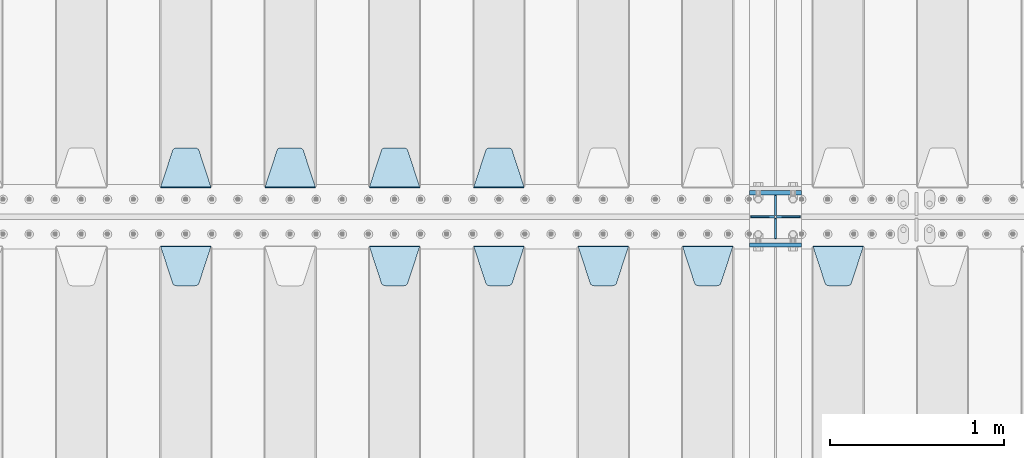
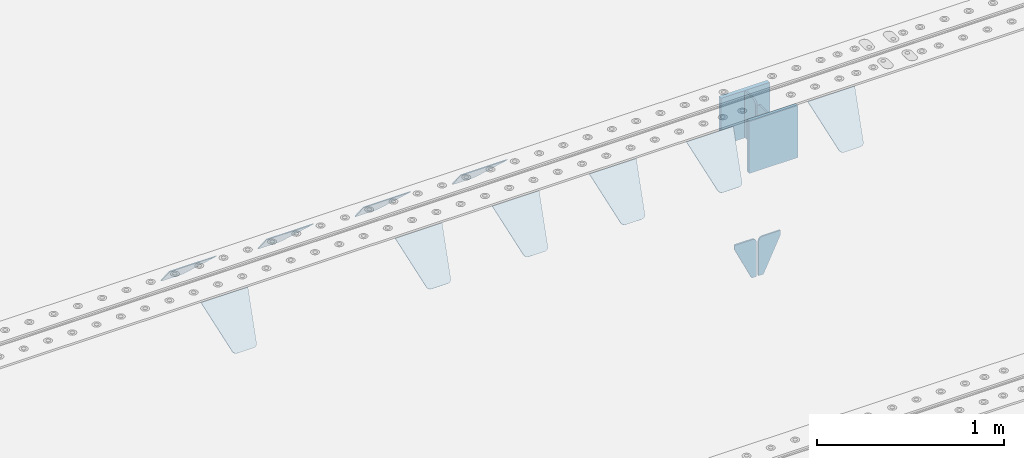
# One storey, part 205 of 240: 16 plates.
"""IFC2X3 building model written with IfcOpenShell, lengths in millimetres."""

from ifc_helpers import new_model, si_unit, frame, origin_with_axes, place, context, subcontext, project, spatial, faceted_brep, material, type_object, element, save


model = new_model("IFC2X3")

# Units and contexts
model_context = context("Model", 3, precision=1e-05, world=origin_with_axes())
body_context = subcontext(model_context, "Body", "Model", "MODEL_VIEW")
ifc_project = project(units=[si_unit("LENGTHUNIT", "METRE", prefix="MILLI"), si_unit("AREAUNIT", "SQUARE_METRE"), si_unit("VOLUMEUNIT", "CUBIC_METRE"), si_unit("MASSUNIT", "GRAM", prefix="KILO"), si_unit("TIMEUNIT", "SECOND"), si_unit("PLANEANGLEUNIT", "RADIAN"), si_unit("SOLIDANGLEUNIT", "STERADIAN"), si_unit("THERMODYNAMICTEMPERATUREUNIT", "DEGREE_CELSIUS"), si_unit("LUMINOUSINTENSITYUNIT", "LUMEN")], contexts=[model_context])

# Site, building, storey
site_placement = place(None, origin_with_axes())
site = spatial("IfcSite", under=ifc_project, at=site_placement, CompositionType="ELEMENT")
building_placement = place(site_placement, origin_with_axes())
building = spatial("IfcBuilding", under=site, at=building_placement, Name="Standard", CompositionType="ELEMENT")
storey_placement = place(building_placement, origin_with_axes())
storey = spatial("IfcBuildingStorey", under=building, at=storey_placement, Name="Undefined", CompositionType="ELEMENT", Elevation=0.0)

# Plates
ifc_material = material(Name="STEEL/S355N")
plate_type_1 = type_object("IfcPlateType", PredefinedType="NOTDEFINED")
plate_1_placement = place(storey_placement, frame((52690.0, 29837.5, -340.000000000044), z_axis=(0.0, 0.0, 1.0), x_axis=(1.0, 0.0, 0.0)))
element("IfcPlate", 1, at=plate_1_placement, inside=storey, type_object=plate_type_1, material=ifc_material, context=body_context, shape_type="Brep", body=[
    faceted_brep([(0.0, -12.5, 0.0), (9.31322574615479e-10, -12.5, 340.0), (9.31322574615479e-10, 12.5, 340.0), (0.0, 12.5, 0.0), (300.0, -12.5, 340.0), (300.0, 12.5, 340.0), (300.0, -12.5, 0.0), (300.0, 12.5, 0.0)], [[[0, 1, 2, 3]], [[1, 4, 5, 2]], [[4, 6, 7, 5]], [[6, 0, 3, 7]], [[5, 7, 3, 2]], [[6, 4, 1, 0]]]),
])
plate_2_placement = place(storey_placement, frame((52690.0, 30137.5, -340.0), z_axis=(0.0, 0.0, 1.0), x_axis=(1.0, 0.0, 0.0)))
element("IfcPlate", 2, at=plate_2_placement, inside=storey, type_object=plate_type_1, material=ifc_material, context=body_context, shape_type="Brep", body=[
    faceted_brep([(0.0, -12.5, 0.0), (0.0, -12.5, 310.0), (0.0, 12.5, 310.0), (0.0, 12.5, 0.0), (300.0, -12.5, 310.0), (300.0, 12.5, 310.0), (300.0, -12.5, 0.0), (300.0, 12.5, 0.0)], [[[0, 1, 2, 3]], [[1, 4, 5, 2]], [[4, 6, 7, 5]], [[6, 0, 3, 7]], [[5, 7, 3, 2]], [[6, 4, 1, 0]]]),
])
plate_type_2 = type_object("IfcPlateType", PredefinedType="NOTDEFINED")
for number, where, z_axis, x_axis in (
    (3, (52840.0, 30008.0, -30.0), (0.0, 0.0, -1.0), (0.0, 1.0, 0.0)),
    (4, (52840.0, 29992.0, -30.0), (0.0, 0.0, -1.0), (0.0, -1.0, 0.0)),
):
    element("IfcPlate", number, at=place(storey_placement, frame(where, z_axis=z_axis, x_axis=x_axis)), inside=storey, type_object=plate_type_2, material=ifc_material, context=body_context, shape_type="Brep", body=[
        faceted_brep([(0.0, -5.0, 30.0), (0.0, -5.0, 306.0), (0.0, 5.0, 306.0), (0.0, 5.0, 30.0), (117.0, -5.0, 306.0), (117.0, 5.0, 306.0), (117.0, -5.0, 0.0), (117.0, 5.0, 0.0), (30.0, -5.0, 0.0), (30.0, 5.0, 0.0), (24.7905546699913, -5.0, 0.455767409633758), (24.7905546699913, 5.0, 0.455767409633758), (19.7393957002278, -5.0, 1.80922137642275), (19.7393957002278, 5.0, 1.80922137642275), (15.0, -5.0, 4.01923788646684), (15.0, 5.0, 4.01923788646684), (10.7163717094008, -5.0, 7.01866670643066), (10.7163717094008, 5.0, 7.01866670643066), (7.01866670643358, -5.0, 10.7163717094038), (7.01866670643358, 5.0, 10.7163717094038), (4.01923788646673, -5.0, 15.0), (4.01923788646673, 5.0, 15.0), (1.80922137642483, -5.0, 19.7393957002299), (1.80922137642483, 5.0, 19.7393957002299), (0.455767409635882, -5.0, 24.7905546699921), (0.455767409635882, 5.0, 24.7905546699921)], [[[0, 1, 2, 3]], [[1, 4, 5, 2]], [[4, 6, 7, 5]], [[6, 8, 9, 7]], [[8, 10, 11, 9]], [[10, 12, 13, 11]], [[12, 14, 15, 13]], [[14, 16, 17, 15]], [[16, 18, 19, 17]], [[18, 20, 21, 19]], [[20, 22, 23, 21]], [[22, 24, 25, 23]], [[24, 0, 3, 25]], [[5, 7, 9, 11, 13, 15, 17, 19, 21, 23, 25, 3, 2]], [[24, 22, 20, 18, 16, 14, 12, 10, 8, 6, 4, 1, 0]]]),
    ])
plate_type_3 = type_object("IfcPlateType", PredefinedType="NOTDEFINED")
for number, where, z_axis, x_axis in (
    (5, (52833.4999999979, 30000.0000000345, -915.000018222273), (0.0, 0.0, -1.0), (-1.0, 0.0, 0.0)),
    (6, (52846.4999999981, 30000.0000000345, -915.000018222273), (0.0, 0.0, -1.0), (1.0, 0.0, 0.0)),
):
    element("IfcPlate", number, at=place(storey_placement, frame(where, z_axis=z_axis, x_axis=x_axis)), inside=storey, type_object=plate_type_3, material=ifc_material, context=body_context, shape_type="Brep", body=[
        faceted_brep([(0.0, -5.0, 27.0), (0.0, -5.0, 250.0), (0.0, 5.0, 250.0), (0.0, 5.0, 27.0), (30.0, -5.0, 250.0), (30.0, 5.0, 250.0), (135.0, -5.0, 30.0), (135.0, 5.0, 30.0), (135.0, -5.0, 0.0), (135.0, 5.0, 0.0), (27.0, -5.0, 0.0), (27.0, 5.0, 0.0), (22.311499202995, -5.0, 0.410190668670339), (22.311499202995, 5.0, 0.410190668670339), (17.7654561302043, -5.0, 1.62829923878053), (17.7654561302043, 5.0, 1.62829923878053), (13.5, -5.0, 3.6173140978201), (13.5, 5.0, 3.6173140978201), (9.64473453846585, -5.0, 6.31680003578754), (9.64473453846585, 5.0, 6.31680003578754), (6.31680003579095, -5.0, 9.64473453846347), (6.31680003579095, 5.0, 9.64473453846347), (3.61731409782078, -5.0, 13.5), (3.61731409782078, 5.0, 13.5), (1.62829923877871, -5.0, 17.765456130207), (1.62829923877871, 5.0, 17.765456130207), (0.410190668670111, -5.0, 22.3114992029929), (0.410190668670111, 5.0, 22.3114992029929)], [[[0, 1, 2, 3]], [[1, 4, 5, 2]], [[4, 6, 7, 5]], [[6, 8, 9, 7]], [[8, 10, 11, 9]], [[10, 12, 13, 11]], [[12, 14, 15, 13]], [[14, 16, 17, 15]], [[16, 18, 19, 17]], [[18, 20, 21, 19]], [[20, 22, 23, 21]], [[22, 24, 25, 23]], [[24, 26, 27, 25]], [[26, 0, 3, 27]], [[5, 7, 9, 11, 13, 15, 17, 19, 21, 23, 25, 27, 3, 2]], [[26, 24, 22, 20, 18, 16, 14, 12, 10, 8, 6, 4, 1, 0]]]),
    ])
plate_type_4 = type_object("IfcPlateType", PredefinedType="NOTDEFINED")
plate_3_placement = place(storey_placement, frame((51395.0, 30168.232233047, -1.76776695296758), z_axis=(0.0, 0.707106781186547, -0.707106781186548), x_axis=(-1.0, 0.0, 0.0)))
element("IfcPlate", 7, at=plate_3_placement, inside=storey, type_object=plate_type_4, material=ifc_material, context=body_context, shape_type="Brep", body=[
    faceted_brep([(0.0, -2.5, 0.0), (69.345504679477, -2.50000000000364, 300.171731424827), (69.345504679477, 2.49999999999636, 300.171731424827), (0.0, 2.5, 0.0), (70.927406119954, -2.50000000000364, 304.897442415397), (70.927406119954, 2.49999999999636, 304.897442415397), (73.3818627772271, -2.50000000000728, 309.234538108525), (73.3818627772271, 2.49999999999636, 309.234538108529), (76.6187032999587, -2.50000000000728, 313.023683126099), (76.6187032999587, 2.49999999999636, 313.023683126103), (80.5190132705029, -2.50000000000364, 316.125672595368), (80.5190132705029, 2.49999999999636, 316.125672595368), (84.9395038596849, -2.50000000000364, 318.426546230472), (84.9395038596849, 2.49999999999636, 318.426546230472), (89.7177759439219, -2.5, 319.841774983277), (89.7177759439219, 2.49999999999636, 319.841774983273), (94.6782862926484, -2.50000000000364, 320.319366455074), (94.6782862926484, 2.49999999999636, 320.319366455074), (195.321713707352, -2.50000000000364, 320.319366455074), (195.321713707352, 2.49999999999636, 320.319366455074), (200.282224056078, -2.50000000000364, 319.841774983273), (200.282224056078, 2.49999999999636, 319.841774983273), (205.060496140315, -2.50000000000364, 318.426546230472), (205.060496140315, 2.49999999999636, 318.426546230472), (209.480986729497, -2.50000000000364, 316.125672595368), (209.480986729497, 2.49999999999636, 316.125672595368), (213.381296700041, -2.50000000000728, 313.023683126099), (213.381296700041, 2.49999999999272, 313.023683126099), (216.618137222766, -2.50000000000364, 309.234538108522), (216.618137222766, 2.49999999999636, 309.234538108522), (219.072593880039, -2.50000000000364, 304.897442415397), (219.072593880039, 2.49999999999636, 304.897442415397), (220.654495320523, -2.50000000000364, 300.171731424827), (220.654495320523, 2.49999999999636, 300.171731424827), (290.0, -2.50000000000364, -3.63797880709171e-12), (290.0, 2.49999999999636, -3.63797880709171e-12)], [[[0, 1, 2, 3]], [[1, 4, 5, 2]], [[4, 6, 7, 5]], [[6, 8, 9, 7]], [[8, 10, 11, 9]], [[10, 12, 13, 11]], [[12, 14, 15, 13]], [[14, 16, 17, 15]], [[16, 18, 19, 17]], [[18, 20, 21, 19]], [[20, 22, 23, 21]], [[22, 24, 25, 23]], [[24, 26, 27, 25]], [[26, 28, 29, 27]], [[28, 30, 31, 29]], [[30, 32, 33, 31]], [[32, 34, 35, 33]], [[34, 0, 3, 35]], [[5, 7, 9, 11, 13, 15, 17, 19, 21, 23, 25, 27, 29, 31, 33, 35, 3, 2]], [[34, 32, 30, 28, 26, 24, 22, 20, 18, 16, 14, 12, 10, 8, 6, 4, 1, 0]]]),
])
plate_4_placement = place(storey_placement, frame((50795.0, 30168.232233047, -1.76776695296758), z_axis=(0.0, 0.707106781186547, -0.707106781186548), x_axis=(-1.0, 0.0, 0.0)))
element("IfcPlate", 8, at=plate_4_placement, inside=storey, type_object=plate_type_4, material=ifc_material, context=body_context, shape_type="Brep", body=[
    faceted_brep([(0.0, -2.5, 0.0), (69.345504679477, -2.50000000000364, 300.171731424827), (69.345504679477, 2.49999999999636, 300.171731424827), (0.0, 2.5, 0.0), (70.927406119954, -2.50000000000364, 304.897442415397), (70.927406119954, 2.49999999999636, 304.897442415397), (73.3818627772271, -2.50000000000728, 309.234538108525), (73.3818627772271, 2.49999999999636, 309.234538108529), (76.6187032999587, -2.50000000000728, 313.023683126099), (76.6187032999587, 2.49999999999636, 313.023683126103), (80.5190132705029, -2.50000000000364, 316.125672595368), (80.5190132705029, 2.49999999999636, 316.125672595368), (84.9395038596849, -2.50000000000364, 318.426546230472), (84.9395038596849, 2.49999999999636, 318.426546230472), (89.7177759439219, -2.5, 319.841774983277), (89.7177759439219, 2.49999999999636, 319.841774983273), (94.6782862926484, -2.50000000000364, 320.319366455074), (94.6782862926484, 2.49999999999636, 320.319366455074), (195.321713707352, -2.50000000000364, 320.319366455074), (195.321713707352, 2.49999999999636, 320.319366455074), (200.282224056078, -2.50000000000364, 319.841774983273), (200.282224056078, 2.49999999999636, 319.841774983273), (205.060496140315, -2.50000000000364, 318.426546230472), (205.060496140315, 2.49999999999636, 318.426546230472), (209.480986729497, -2.50000000000364, 316.125672595368), (209.480986729497, 2.49999999999636, 316.125672595368), (213.381296700041, -2.50000000000728, 313.023683126099), (213.381296700041, 2.49999999999272, 313.023683126099), (216.618137222766, -2.50000000000364, 309.234538108522), (216.618137222766, 2.49999999999636, 309.234538108522), (219.072593880039, -2.50000000000364, 304.897442415397), (219.072593880039, 2.49999999999636, 304.897442415397), (220.654495320523, -2.50000000000364, 300.171731424827), (220.654495320523, 2.49999999999636, 300.171731424827), (290.0, -2.50000000000364, -3.63797880709171e-12), (290.0, 2.49999999999636, -3.63797880709171e-12)], [[[0, 1, 2, 3]], [[1, 4, 5, 2]], [[4, 6, 7, 5]], [[6, 8, 9, 7]], [[8, 10, 11, 9]], [[10, 12, 13, 11]], [[12, 14, 15, 13]], [[14, 16, 17, 15]], [[16, 18, 19, 17]], [[18, 20, 21, 19]], [[20, 22, 23, 21]], [[22, 24, 25, 23]], [[24, 26, 27, 25]], [[26, 28, 29, 27]], [[28, 30, 31, 29]], [[30, 32, 33, 31]], [[32, 34, 35, 33]], [[34, 0, 3, 35]], [[5, 7, 9, 11, 13, 15, 17, 19, 21, 23, 25, 27, 29, 31, 33, 35, 3, 2]], [[34, 32, 30, 28, 26, 24, 22, 20, 18, 16, 14, 12, 10, 8, 6, 4, 1, 0]]]),
])
plate_5_placement = place(storey_placement, frame((50195.0, 30168.232233047, -1.76776695296758), z_axis=(0.0, 0.707106781186547, -0.707106781186548), x_axis=(-1.0, 0.0, 0.0)))
element("IfcPlate", 9, at=plate_5_placement, inside=storey, type_object=plate_type_4, material=ifc_material, context=body_context, shape_type="Brep", body=[
    faceted_brep([(0.0, -2.5, 0.0), (69.345504679477, -2.50000000000364, 300.171731424827), (69.345504679477, 2.49999999999636, 300.171731424827), (0.0, 2.5, 0.0), (70.927406119954, -2.50000000000364, 304.897442415397), (70.927406119954, 2.49999999999636, 304.897442415397), (73.3818627772271, -2.50000000000728, 309.234538108525), (73.3818627772271, 2.49999999999636, 309.234538108529), (76.6187032999587, -2.50000000000728, 313.023683126099), (76.6187032999587, 2.49999999999636, 313.023683126103), (80.5190132705029, -2.50000000000364, 316.125672595368), (80.5190132705029, 2.49999999999636, 316.125672595368), (84.9395038596849, -2.50000000000364, 318.426546230472), (84.9395038596849, 2.49999999999636, 318.426546230472), (89.7177759439219, -2.5, 319.841774983277), (89.7177759439219, 2.49999999999636, 319.841774983273), (94.6782862926484, -2.50000000000364, 320.319366455074), (94.6782862926484, 2.49999999999636, 320.319366455074), (195.321713707352, -2.50000000000364, 320.319366455074), (195.321713707352, 2.49999999999636, 320.319366455074), (200.282224056078, -2.50000000000364, 319.841774983273), (200.282224056078, 2.49999999999636, 319.841774983273), (205.060496140315, -2.50000000000364, 318.426546230472), (205.060496140315, 2.49999999999636, 318.426546230472), (209.480986729497, -2.50000000000364, 316.125672595368), (209.480986729497, 2.49999999999636, 316.125672595368), (213.381296700041, -2.50000000000728, 313.023683126099), (213.381296700041, 2.49999999999272, 313.023683126099), (216.618137222766, -2.50000000000364, 309.234538108522), (216.618137222766, 2.49999999999636, 309.234538108522), (219.072593880039, -2.50000000000364, 304.897442415397), (219.072593880039, 2.49999999999636, 304.897442415397), (220.654495320523, -2.50000000000364, 300.171731424827), (220.654495320523, 2.49999999999636, 300.171731424827), (290.0, -2.50000000000364, -3.63797880709171e-12), (290.0, 2.49999999999636, -3.63797880709171e-12)], [[[0, 1, 2, 3]], [[1, 4, 5, 2]], [[4, 6, 7, 5]], [[6, 8, 9, 7]], [[8, 10, 11, 9]], [[10, 12, 13, 11]], [[12, 14, 15, 13]], [[14, 16, 17, 15]], [[16, 18, 19, 17]], [[18, 20, 21, 19]], [[20, 22, 23, 21]], [[22, 24, 25, 23]], [[24, 26, 27, 25]], [[26, 28, 29, 27]], [[28, 30, 31, 29]], [[30, 32, 33, 31]], [[32, 34, 35, 33]], [[34, 0, 3, 35]], [[5, 7, 9, 11, 13, 15, 17, 19, 21, 23, 25, 27, 29, 31, 33, 35, 3, 2]], [[34, 32, 30, 28, 26, 24, 22, 20, 18, 16, 14, 12, 10, 8, 6, 4, 1, 0]]]),
])
plate_6_placement = place(storey_placement, frame((49595.0, 30168.232233047, -1.76776695296758), z_axis=(0.0, 0.707106781186547, -0.707106781186548), x_axis=(-1.0, 0.0, 0.0)))
element("IfcPlate", 10, at=plate_6_placement, inside=storey, type_object=plate_type_4, material=ifc_material, context=body_context, shape_type="Brep", body=[
    faceted_brep([(0.0, -2.5, 0.0), (69.345504679477, -2.50000000000364, 300.171731424827), (69.345504679477, 2.49999999999636, 300.171731424827), (0.0, 2.5, 0.0), (70.927406119954, -2.50000000000364, 304.897442415397), (70.927406119954, 2.49999999999636, 304.897442415397), (73.3818627772271, -2.50000000000728, 309.234538108525), (73.3818627772271, 2.49999999999636, 309.234538108529), (76.6187032999587, -2.50000000000728, 313.023683126099), (76.6187032999587, 2.49999999999636, 313.023683126103), (80.5190132705029, -2.50000000000364, 316.125672595368), (80.5190132705029, 2.49999999999636, 316.125672595368), (84.9395038596849, -2.50000000000364, 318.426546230472), (84.9395038596849, 2.49999999999636, 318.426546230472), (89.7177759439219, -2.5, 319.841774983277), (89.7177759439219, 2.49999999999636, 319.841774983273), (94.6782862926484, -2.50000000000364, 320.319366455074), (94.6782862926484, 2.49999999999636, 320.319366455074), (195.321713707352, -2.50000000000364, 320.319366455074), (195.321713707352, 2.49999999999636, 320.319366455074), (200.282224056078, -2.50000000000364, 319.841774983273), (200.282224056078, 2.49999999999636, 319.841774983273), (205.060496140315, -2.50000000000364, 318.426546230472), (205.060496140315, 2.49999999999636, 318.426546230472), (209.480986729497, -2.50000000000364, 316.125672595368), (209.480986729497, 2.49999999999636, 316.125672595368), (213.381296700041, -2.50000000000728, 313.023683126099), (213.381296700041, 2.49999999999272, 313.023683126099), (216.618137222766, -2.50000000000364, 309.234538108522), (216.618137222766, 2.49999999999636, 309.234538108522), (219.072593880039, -2.50000000000364, 304.897442415397), (219.072593880039, 2.49999999999636, 304.897442415397), (220.654495320523, -2.50000000000364, 300.171731424827), (220.654495320523, 2.49999999999636, 300.171731424827), (290.0, -2.50000000000364, -3.63797880709171e-12), (290.0, 2.49999999999636, -3.63797880709171e-12)], [[[0, 1, 2, 3]], [[1, 4, 5, 2]], [[4, 6, 7, 5]], [[6, 8, 9, 7]], [[8, 10, 11, 9]], [[10, 12, 13, 11]], [[12, 14, 15, 13]], [[14, 16, 17, 15]], [[16, 18, 19, 17]], [[18, 20, 21, 19]], [[20, 22, 23, 21]], [[22, 24, 25, 23]], [[24, 26, 27, 25]], [[26, 28, 29, 27]], [[28, 30, 31, 29]], [[30, 32, 33, 31]], [[32, 34, 35, 33]], [[34, 0, 3, 35]], [[5, 7, 9, 11, 13, 15, 17, 19, 21, 23, 25, 27, 29, 31, 33, 35, 3, 2]], [[34, 32, 30, 28, 26, 24, 22, 20, 18, 16, 14, 12, 10, 8, 6, 4, 1, 0]]]),
])
plate_7_placement = place(storey_placement, frame((53055.0, 29831.767766956, -1.76776695296758), z_axis=(0.0, -0.707106781186547, -0.707106781186548), x_axis=(1.0, 0.0, 0.0)))
element("IfcPlate", 11, at=plate_7_placement, inside=storey, type_object=plate_type_4, material=ifc_material, context=body_context, shape_type="Brep", body=[
    faceted_brep([(0.0, -2.5, 0.0), (69.345504679477, -2.50000000000364, 300.171731424827), (69.345504679477, 2.49999999999636, 300.171731424827), (0.0, 2.5, 0.0), (70.927406119954, -2.50000000000364, 304.897442415397), (70.927406119954, 2.49999999999636, 304.897442415397), (73.3818627772271, -2.50000000000728, 309.234538108525), (73.3818627772271, 2.49999999999636, 309.234538108529), (76.6187032999587, -2.50000000000728, 313.023683126099), (76.6187032999587, 2.49999999999636, 313.023683126103), (80.5190132705029, -2.50000000000364, 316.125672595368), (80.5190132705029, 2.49999999999636, 316.125672595368), (84.9395038596849, -2.50000000000364, 318.426546230472), (84.9395038596849, 2.49999999999636, 318.426546230472), (89.7177759439219, -2.5, 319.841774983277), (89.7177759439219, 2.49999999999636, 319.841774983273), (94.6782862926484, -2.50000000000364, 320.319366455074), (94.6782862926484, 2.49999999999636, 320.319366455074), (195.321713707352, -2.50000000000364, 320.319366455074), (195.321713707352, 2.49999999999636, 320.319366455074), (200.282224056078, -2.50000000000364, 319.841774983273), (200.282224056078, 2.49999999999636, 319.841774983273), (205.060496140315, -2.50000000000364, 318.426546230472), (205.060496140315, 2.49999999999636, 318.426546230472), (209.480986729497, -2.50000000000364, 316.125672595368), (209.480986729497, 2.49999999999636, 316.125672595368), (213.381296700041, -2.50000000000728, 313.023683126099), (213.381296700041, 2.49999999999272, 313.023683126099), (216.618137222766, -2.50000000000364, 309.234538108522), (216.618137222766, 2.49999999999636, 309.234538108522), (219.072593880039, -2.50000000000364, 304.897442415397), (219.072593880039, 2.49999999999636, 304.897442415397), (220.654495320523, -2.50000000000364, 300.171731424827), (220.654495320523, 2.49999999999636, 300.171731424827), (290.0, -2.50000000000364, -3.63797880709171e-12), (290.0, 2.49999999999636, -3.63797880709171e-12)], [[[0, 1, 2, 3]], [[1, 4, 5, 2]], [[4, 6, 7, 5]], [[6, 8, 9, 7]], [[8, 10, 11, 9]], [[10, 12, 13, 11]], [[12, 14, 15, 13]], [[14, 16, 17, 15]], [[16, 18, 19, 17]], [[18, 20, 21, 19]], [[20, 22, 23, 21]], [[22, 24, 25, 23]], [[24, 26, 27, 25]], [[26, 28, 29, 27]], [[28, 30, 31, 29]], [[30, 32, 33, 31]], [[32, 34, 35, 33]], [[34, 0, 3, 35]], [[5, 7, 9, 11, 13, 15, 17, 19, 21, 23, 25, 27, 29, 31, 33, 35, 3, 2]], [[34, 32, 30, 28, 26, 24, 22, 20, 18, 16, 14, 12, 10, 8, 6, 4, 1, 0]]]),
])
plate_8_placement = place(storey_placement, frame((52305.0, 29831.767766956, -1.76776695296758), z_axis=(0.0, -0.707106781186547, -0.707106781186548), x_axis=(1.0, 0.0, 0.0)))
element("IfcPlate", 12, at=plate_8_placement, inside=storey, type_object=plate_type_4, material=ifc_material, context=body_context, shape_type="Brep", body=[
    faceted_brep([(0.0, -2.5, 0.0), (69.345504679477, -2.50000000000364, 300.171731424827), (69.345504679477, 2.49999999999636, 300.171731424827), (0.0, 2.5, 0.0), (70.927406119954, -2.50000000000364, 304.897442415397), (70.927406119954, 2.49999999999636, 304.897442415397), (73.3818627772271, -2.50000000000728, 309.234538108525), (73.3818627772271, 2.49999999999636, 309.234538108529), (76.6187032999587, -2.50000000000728, 313.023683126099), (76.6187032999587, 2.49999999999636, 313.023683126103), (80.5190132705029, -2.50000000000364, 316.125672595368), (80.5190132705029, 2.49999999999636, 316.125672595368), (84.9395038596849, -2.50000000000364, 318.426546230472), (84.9395038596849, 2.49999999999636, 318.426546230472), (89.7177759439219, -2.5, 319.841774983277), (89.7177759439219, 2.49999999999636, 319.841774983273), (94.6782862926484, -2.50000000000364, 320.319366455074), (94.6782862926484, 2.49999999999636, 320.319366455074), (195.321713707352, -2.50000000000364, 320.319366455074), (195.321713707352, 2.49999999999636, 320.319366455074), (200.282224056078, -2.50000000000364, 319.841774983273), (200.282224056078, 2.49999999999636, 319.841774983273), (205.060496140315, -2.50000000000364, 318.426546230472), (205.060496140315, 2.49999999999636, 318.426546230472), (209.480986729497, -2.50000000000364, 316.125672595368), (209.480986729497, 2.49999999999636, 316.125672595368), (213.381296700041, -2.50000000000728, 313.023683126099), (213.381296700041, 2.49999999999272, 313.023683126099), (216.618137222766, -2.50000000000364, 309.234538108522), (216.618137222766, 2.49999999999636, 309.234538108522), (219.072593880039, -2.50000000000364, 304.897442415397), (219.072593880039, 2.49999999999636, 304.897442415397), (220.654495320523, -2.50000000000364, 300.171731424827), (220.654495320523, 2.49999999999636, 300.171731424827), (290.0, -2.50000000000364, -3.63797880709171e-12), (290.0, 2.49999999999636, -3.63797880709171e-12)], [[[0, 1, 2, 3]], [[1, 4, 5, 2]], [[4, 6, 7, 5]], [[6, 8, 9, 7]], [[8, 10, 11, 9]], [[10, 12, 13, 11]], [[12, 14, 15, 13]], [[14, 16, 17, 15]], [[16, 18, 19, 17]], [[18, 20, 21, 19]], [[20, 22, 23, 21]], [[22, 24, 25, 23]], [[24, 26, 27, 25]], [[26, 28, 29, 27]], [[28, 30, 31, 29]], [[30, 32, 33, 31]], [[32, 34, 35, 33]], [[34, 0, 3, 35]], [[5, 7, 9, 11, 13, 15, 17, 19, 21, 23, 25, 27, 29, 31, 33, 35, 3, 2]], [[34, 32, 30, 28, 26, 24, 22, 20, 18, 16, 14, 12, 10, 8, 6, 4, 1, 0]]]),
])
plate_9_placement = place(storey_placement, frame((51705.0, 29831.767766956, -1.76776695296758), z_axis=(0.0, -0.707106781186547, -0.707106781186548), x_axis=(1.0, 0.0, 0.0)))
element("IfcPlate", 13, at=plate_9_placement, inside=storey, type_object=plate_type_4, material=ifc_material, context=body_context, shape_type="Brep", body=[
    faceted_brep([(0.0, -2.5, 0.0), (69.345504679477, -2.50000000000364, 300.171731424827), (69.345504679477, 2.49999999999636, 300.171731424827), (0.0, 2.5, 0.0), (70.927406119954, -2.50000000000364, 304.897442415397), (70.927406119954, 2.49999999999636, 304.897442415397), (73.3818627772271, -2.50000000000728, 309.234538108525), (73.3818627772271, 2.49999999999636, 309.234538108529), (76.6187032999587, -2.50000000000728, 313.023683126099), (76.6187032999587, 2.49999999999636, 313.023683126103), (80.5190132705029, -2.50000000000364, 316.125672595368), (80.5190132705029, 2.49999999999636, 316.125672595368), (84.9395038596849, -2.50000000000364, 318.426546230472), (84.9395038596849, 2.49999999999636, 318.426546230472), (89.7177759439219, -2.5, 319.841774983277), (89.7177759439219, 2.49999999999636, 319.841774983273), (94.6782862926484, -2.50000000000364, 320.319366455074), (94.6782862926484, 2.49999999999636, 320.319366455074), (195.321713707352, -2.50000000000364, 320.319366455074), (195.321713707352, 2.49999999999636, 320.319366455074), (200.282224056078, -2.50000000000364, 319.841774983273), (200.282224056078, 2.49999999999636, 319.841774983273), (205.060496140315, -2.50000000000364, 318.426546230472), (205.060496140315, 2.49999999999636, 318.426546230472), (209.480986729497, -2.50000000000364, 316.125672595368), (209.480986729497, 2.49999999999636, 316.125672595368), (213.381296700041, -2.50000000000728, 313.023683126099), (213.381296700041, 2.49999999999272, 313.023683126099), (216.618137222766, -2.50000000000364, 309.234538108522), (216.618137222766, 2.49999999999636, 309.234538108522), (219.072593880039, -2.50000000000364, 304.897442415397), (219.072593880039, 2.49999999999636, 304.897442415397), (220.654495320523, -2.50000000000364, 300.171731424827), (220.654495320523, 2.49999999999636, 300.171731424827), (290.0, -2.50000000000364, -3.63797880709171e-12), (290.0, 2.49999999999636, -3.63797880709171e-12)], [[[0, 1, 2, 3]], [[1, 4, 5, 2]], [[4, 6, 7, 5]], [[6, 8, 9, 7]], [[8, 10, 11, 9]], [[10, 12, 13, 11]], [[12, 14, 15, 13]], [[14, 16, 17, 15]], [[16, 18, 19, 17]], [[18, 20, 21, 19]], [[20, 22, 23, 21]], [[22, 24, 25, 23]], [[24, 26, 27, 25]], [[26, 28, 29, 27]], [[28, 30, 31, 29]], [[30, 32, 33, 31]], [[32, 34, 35, 33]], [[34, 0, 3, 35]], [[5, 7, 9, 11, 13, 15, 17, 19, 21, 23, 25, 27, 29, 31, 33, 35, 3, 2]], [[34, 32, 30, 28, 26, 24, 22, 20, 18, 16, 14, 12, 10, 8, 6, 4, 1, 0]]]),
])
plate_10_placement = place(storey_placement, frame((51105.0, 29831.767766956, -1.76776695296758), z_axis=(0.0, -0.707106781186547, -0.707106781186548), x_axis=(1.0, 0.0, 0.0)))
element("IfcPlate", 14, at=plate_10_placement, inside=storey, type_object=plate_type_4, material=ifc_material, context=body_context, shape_type="Brep", body=[
    faceted_brep([(0.0, -2.5, 0.0), (69.345504679477, -2.50000000000364, 300.171731424827), (69.345504679477, 2.49999999999636, 300.171731424827), (0.0, 2.5, 0.0), (70.927406119954, -2.50000000000364, 304.897442415397), (70.927406119954, 2.49999999999636, 304.897442415397), (73.3818627772271, -2.50000000000728, 309.234538108525), (73.3818627772271, 2.49999999999636, 309.234538108529), (76.6187032999587, -2.50000000000728, 313.023683126099), (76.6187032999587, 2.49999999999636, 313.023683126103), (80.5190132705029, -2.50000000000364, 316.125672595368), (80.5190132705029, 2.49999999999636, 316.125672595368), (84.9395038596849, -2.50000000000364, 318.426546230472), (84.9395038596849, 2.49999999999636, 318.426546230472), (89.7177759439219, -2.5, 319.841774983277), (89.7177759439219, 2.49999999999636, 319.841774983273), (94.6782862926484, -2.50000000000364, 320.319366455074), (94.6782862926484, 2.49999999999636, 320.319366455074), (195.321713707352, -2.50000000000364, 320.319366455074), (195.321713707352, 2.49999999999636, 320.319366455074), (200.282224056078, -2.50000000000364, 319.841774983273), (200.282224056078, 2.49999999999636, 319.841774983273), (205.060496140315, -2.50000000000364, 318.426546230472), (205.060496140315, 2.49999999999636, 318.426546230472), (209.480986729497, -2.50000000000364, 316.125672595368), (209.480986729497, 2.49999999999636, 316.125672595368), (213.381296700041, -2.50000000000728, 313.023683126099), (213.381296700041, 2.49999999999272, 313.023683126099), (216.618137222766, -2.50000000000364, 309.234538108522), (216.618137222766, 2.49999999999636, 309.234538108522), (219.072593880039, -2.50000000000364, 304.897442415397), (219.072593880039, 2.49999999999636, 304.897442415397), (220.654495320523, -2.50000000000364, 300.171731424827), (220.654495320523, 2.49999999999636, 300.171731424827), (290.0, -2.50000000000364, -3.63797880709171e-12), (290.0, 2.49999999999636, -3.63797880709171e-12)], [[[0, 1, 2, 3]], [[1, 4, 5, 2]], [[4, 6, 7, 5]], [[6, 8, 9, 7]], [[8, 10, 11, 9]], [[10, 12, 13, 11]], [[12, 14, 15, 13]], [[14, 16, 17, 15]], [[16, 18, 19, 17]], [[18, 20, 21, 19]], [[20, 22, 23, 21]], [[22, 24, 25, 23]], [[24, 26, 27, 25]], [[26, 28, 29, 27]], [[28, 30, 31, 29]], [[30, 32, 33, 31]], [[32, 34, 35, 33]], [[34, 0, 3, 35]], [[5, 7, 9, 11, 13, 15, 17, 19, 21, 23, 25, 27, 29, 31, 33, 35, 3, 2]], [[34, 32, 30, 28, 26, 24, 22, 20, 18, 16, 14, 12, 10, 8, 6, 4, 1, 0]]]),
])
plate_11_placement = place(storey_placement, frame((50505.0, 29831.767766956, -1.76776695296758), z_axis=(0.0, -0.707106781186547, -0.707106781186548), x_axis=(1.0, 0.0, 0.0)))
element("IfcPlate", 15, at=plate_11_placement, inside=storey, type_object=plate_type_4, material=ifc_material, context=body_context, shape_type="Brep", body=[
    faceted_brep([(0.0, -2.5, 0.0), (69.345504679477, -2.50000000000364, 300.171731424827), (69.345504679477, 2.49999999999636, 300.171731424827), (0.0, 2.5, 0.0), (70.927406119954, -2.50000000000364, 304.897442415397), (70.927406119954, 2.49999999999636, 304.897442415397), (73.3818627772271, -2.50000000000728, 309.234538108525), (73.3818627772271, 2.49999999999636, 309.234538108529), (76.6187032999587, -2.50000000000728, 313.023683126099), (76.6187032999587, 2.49999999999636, 313.023683126103), (80.5190132705029, -2.50000000000364, 316.125672595368), (80.5190132705029, 2.49999999999636, 316.125672595368), (84.9395038596849, -2.50000000000364, 318.426546230472), (84.9395038596849, 2.49999999999636, 318.426546230472), (89.7177759439219, -2.5, 319.841774983277), (89.7177759439219, 2.49999999999636, 319.841774983273), (94.6782862926484, -2.50000000000364, 320.319366455074), (94.6782862926484, 2.49999999999636, 320.319366455074), (195.321713707352, -2.50000000000364, 320.319366455074), (195.321713707352, 2.49999999999636, 320.319366455074), (200.282224056078, -2.50000000000364, 319.841774983273), (200.282224056078, 2.49999999999636, 319.841774983273), (205.060496140315, -2.50000000000364, 318.426546230472), (205.060496140315, 2.49999999999636, 318.426546230472), (209.480986729497, -2.50000000000364, 316.125672595368), (209.480986729497, 2.49999999999636, 316.125672595368), (213.381296700041, -2.50000000000728, 313.023683126099), (213.381296700041, 2.49999999999272, 313.023683126099), (216.618137222766, -2.50000000000364, 309.234538108522), (216.618137222766, 2.49999999999636, 309.234538108522), (219.072593880039, -2.50000000000364, 304.897442415397), (219.072593880039, 2.49999999999636, 304.897442415397), (220.654495320523, -2.50000000000364, 300.171731424827), (220.654495320523, 2.49999999999636, 300.171731424827), (290.0, -2.50000000000364, -3.63797880709171e-12), (290.0, 2.49999999999636, -3.63797880709171e-12)], [[[0, 1, 2, 3]], [[1, 4, 5, 2]], [[4, 6, 7, 5]], [[6, 8, 9, 7]], [[8, 10, 11, 9]], [[10, 12, 13, 11]], [[12, 14, 15, 13]], [[14, 16, 17, 15]], [[16, 18, 19, 17]], [[18, 20, 21, 19]], [[20, 22, 23, 21]], [[22, 24, 25, 23]], [[24, 26, 27, 25]], [[26, 28, 29, 27]], [[28, 30, 31, 29]], [[30, 32, 33, 31]], [[32, 34, 35, 33]], [[34, 0, 3, 35]], [[5, 7, 9, 11, 13, 15, 17, 19, 21, 23, 25, 27, 29, 31, 33, 35, 3, 2]], [[34, 32, 30, 28, 26, 24, 22, 20, 18, 16, 14, 12, 10, 8, 6, 4, 1, 0]]]),
])
plate_12_placement = place(storey_placement, frame((49305.0, 29831.767766956, -1.76776695296758), z_axis=(0.0, -0.707106781186547, -0.707106781186548), x_axis=(1.0, 0.0, 0.0)))
element("IfcPlate", 16, at=plate_12_placement, inside=storey, type_object=plate_type_4, material=ifc_material, context=body_context, shape_type="Brep", body=[
    faceted_brep([(0.0, -2.5, 0.0), (69.345504679477, -2.50000000000364, 300.171731424827), (69.345504679477, 2.49999999999636, 300.171731424827), (0.0, 2.5, 0.0), (70.927406119954, -2.50000000000364, 304.897442415397), (70.927406119954, 2.49999999999636, 304.897442415397), (73.3818627772271, -2.50000000000728, 309.234538108525), (73.3818627772271, 2.49999999999636, 309.234538108529), (76.6187032999587, -2.50000000000728, 313.023683126099), (76.6187032999587, 2.49999999999636, 313.023683126103), (80.5190132705029, -2.50000000000364, 316.125672595368), (80.5190132705029, 2.49999999999636, 316.125672595368), (84.9395038596849, -2.50000000000364, 318.426546230472), (84.9395038596849, 2.49999999999636, 318.426546230472), (89.7177759439219, -2.5, 319.841774983277), (89.7177759439219, 2.49999999999636, 319.841774983273), (94.6782862926484, -2.50000000000364, 320.319366455074), (94.6782862926484, 2.49999999999636, 320.319366455074), (195.321713707352, -2.50000000000364, 320.319366455074), (195.321713707352, 2.49999999999636, 320.319366455074), (200.282224056078, -2.50000000000364, 319.841774983273), (200.282224056078, 2.49999999999636, 319.841774983273), (205.060496140315, -2.50000000000364, 318.426546230472), (205.060496140315, 2.49999999999636, 318.426546230472), (209.480986729497, -2.50000000000364, 316.125672595368), (209.480986729497, 2.49999999999636, 316.125672595368), (213.381296700041, -2.50000000000728, 313.023683126099), (213.381296700041, 2.49999999999272, 313.023683126099), (216.618137222766, -2.50000000000364, 309.234538108522), (216.618137222766, 2.49999999999636, 309.234538108522), (219.072593880039, -2.50000000000364, 304.897442415397), (219.072593880039, 2.49999999999636, 304.897442415397), (220.654495320523, -2.50000000000364, 300.171731424827), (220.654495320523, 2.49999999999636, 300.171731424827), (290.0, -2.50000000000364, -3.63797880709171e-12), (290.0, 2.49999999999636, -3.63797880709171e-12)], [[[0, 1, 2, 3]], [[1, 4, 5, 2]], [[4, 6, 7, 5]], [[6, 8, 9, 7]], [[8, 10, 11, 9]], [[10, 12, 13, 11]], [[12, 14, 15, 13]], [[14, 16, 17, 15]], [[16, 18, 19, 17]], [[18, 20, 21, 19]], [[20, 22, 23, 21]], [[22, 24, 25, 23]], [[24, 26, 27, 25]], [[26, 28, 29, 27]], [[28, 30, 31, 29]], [[30, 32, 33, 31]], [[32, 34, 35, 33]], [[34, 0, 3, 35]], [[5, 7, 9, 11, 13, 15, 17, 19, 21, 23, 25, 27, 29, 31, 33, 35, 3, 2]], [[34, 32, 30, 28, 26, 24, 22, 20, 18, 16, 14, 12, 10, 8, 6, 4, 1, 0]]]),
])

save(model, "model.ifc")
